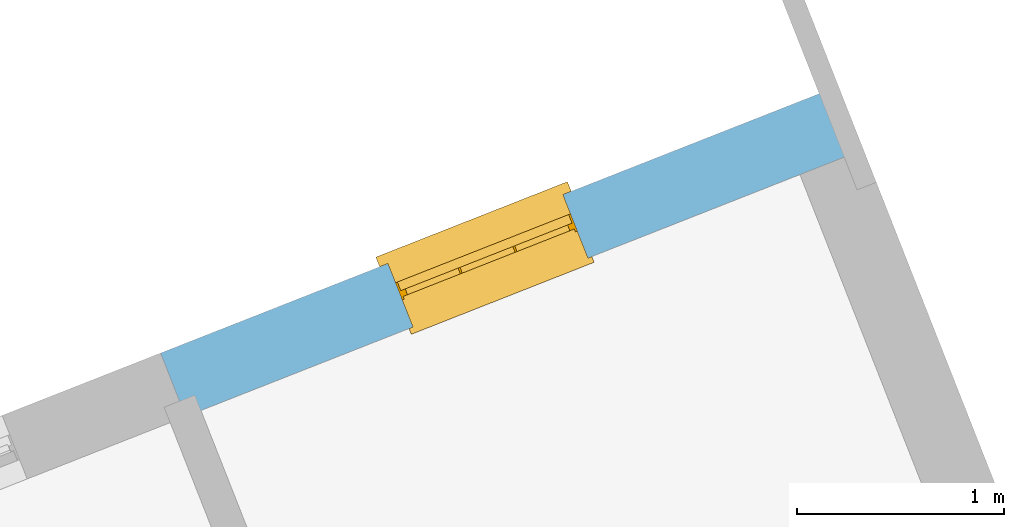
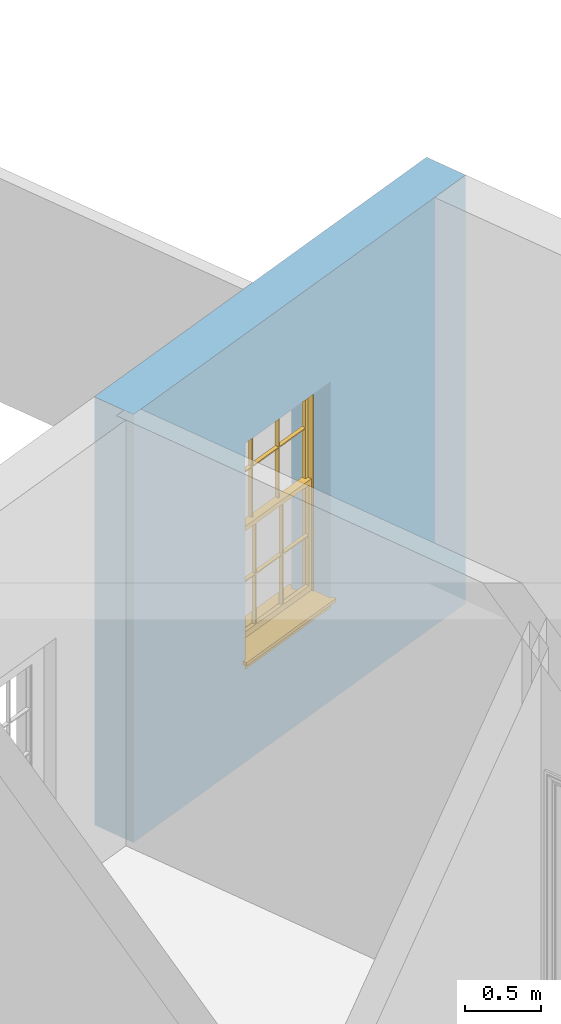
# One storey, part 7 of 8: 1 window, 1 opening, plus 1 element that does not belong to this part.
"""IFC2X3 building model written with IfcOpenShell, lengths in metres."""

from ifc_helpers import new_model, si_unit, frame, origin, place, context, subcontext, project, spatial, polyline, outline, extrude, faceted_brep, material, layer, layer_set, layer_usage, element, fill, save


model = new_model("IFC2X3")

# Units and contexts
model_context = context("Model", 3, world=origin())
body_context = subcontext(model_context, "Body", "Model", "MODEL_VIEW")
ifc_project = project(units=[si_unit("PLANEANGLEUNIT", "RADIAN"), si_unit("MASSUNIT", "GRAM", prefix="KILO"), si_unit("FORCEUNIT", "NEWTON", prefix="KILO"), si_unit("LENGTHUNIT", "METRE")], contexts=[model_context])

# Site, building, storey
site_placement = place(None, origin())
site = spatial("IfcSite", under=ifc_project, at=site_placement, CompositionType="ELEMENT")
building_placement = place(None, origin())
building = spatial("IfcBuilding", under=site, at=building_placement, Name="Building plot-4", CompositionType="ELEMENT")
storey_placement = place(None, frame((0.0, 0.0, 3.0)))
storey = spatial("IfcBuildingStorey", under=building, at=storey_placement, Name="Floor 0", CompositionType="ELEMENT", Elevation=3.0)

# Wall, opening, window
ifc_material = material(Name="Masonry")
ifc_layer = layer(ifc_material, 0.33, ventilated=False)
ifc_layer_set = layer_set([ifc_layer], Name="My Wall")
ifc_layer_usage = layer_usage(ifc_layer_set, "AXIS2", "NEGATIVE", 0.08)
wall_placement = place(storey_placement, origin())
wall = element("IfcWallStandardCase", 1, at=wall_placement, inside=storey, material=ifc_layer_usage, Name="exterior", context=body_context, shape_type="SweptSolid", body=[
    extrude(outline(polyline([(55.3138387008242, 55.0638365529384), (55.192917321505, 55.3708838131828), (51.9157706887258, 54.0802776349957), (52.0366920680449, 53.7732303747513), (55.3138387008242, 55.0638365529384)])), origin(), (0.0, 0.0, 1.0), 3.45),
])
opening_placement = place(storey_placement, frame((0.0, 0.0, 0.75)))
opening = element("IfcOpeningElement", 2, at=opening_placement, cuts=wall, Name="Opening", ObjectType="Opening", context=body_context, shape_type="SweptSolid", body=[
    extrude(outline(polyline([(53.8613912653598, 54.8465021034084), (53.0146851840799, 54.5130522392253), (53.1356065633991, 54.2060049789809), (53.9823126446789, 54.539454843164), (53.8613912653598, 54.8465021034084)])), origin(), (0.0, 0.0, 1.0), 1.82),
])
window_placement = place(storey_placement, frame((53.9529983709046, 54.6138905426172, 0.75), z_axis=(0.0, 0.0, 1.0), x_axis=(-0.846706081279848, -0.333449864183102, 0.0)))
window = element("IfcWindow", 3, at=window_placement, inside=storey, Name="living window", OverallHeight=1.82, OverallWidth=0.91, context=body_context, shape_type="Brep", held_by="IfcProductRepresentation", body=[
    faceted_brep([(0.033125, -0.105, 0.975209), (0.01, -0.105, 0.975209), (0.033125, -0.105, 1.376042), (0.876875, -0.105, 0.975209), (0.876875, -0.105, 1.376042), (0.9, -0.105, 0.975209), (0.876875, -0.105, 1.386042), (0.876875, -0.105, 1.786875), (0.9, -0.105, 1.81), (0.033125, -0.105, 1.786875), (0.033125, -0.105, 1.386042), (0.01, -0.105, 1.81), (0.876875, -0.135, 1.376042), (0.876875, -0.135, 0.975209), (0.9, -0.135, 0.937083), (0.033125, -0.135, 1.786875), (0.01, -0.135, 1.81), (0.033125, -0.135, 1.386042), (0.01, -0.135, 0.937083), (0.033125, -0.135, 0.975209), (0.033125, -0.135, 1.376042), (0.876875, -0.135, 1.786875), (0.876875, -0.135, 1.386042), (0.9, -0.135, 1.81), (0.033125, -0.105, 0.937083), (0.01, -0.105, 0.937083), (0.033125, -0.105, 0.53625), (0.876875, -0.105, 0.937083), (0.876875, -0.105, 0.53625), (0.9, -0.105, 0.937083), (0.876875, -0.105, 0.52625), (0.876875, -0.105, 0.125417), (0.9, -0.105, 0.077167), (0.033125, -0.105, 0.125417), (0.033125, -0.105, 0.52625), (0.01, -0.105, 0.077167), (-0.0425, -0.25, 0.01), (-0.0425, -0.3, 0.001667), (0.0, -0.25, 0.01), (0.9525, -0.25, 0.01), (0.91, -0.25, 0.01), (0.9525, -0.3, 0.001667), (-0.02, 0.08, 0.077167), (0.0, 0.08, 0.077167), (-0.02, 0.11, 0.077167), (0.0, -0.06, 0.077167), (0.01, -0.06, 0.077167), (0.91, -0.06, 0.077167), (0.91, 0.08, 0.077167), (0.9, -0.06, 0.077167), (0.93, 0.08, 0.077167), (0.93, 0.11, 0.077167), (0.01, -0.075, 0.975209), (0.9, -0.075, 0.975209), (0.876875, -0.075, 0.125417), (0.876875, -0.075, 0.52625), (0.9, -0.075, 0.077167), (0.876875, -0.075, 0.53625), (0.876875, -0.075, 0.937083), (0.033125, -0.075, 0.125417), (0.01, -0.075, 0.077167), (0.033125, -0.075, 0.52625), (0.033125, -0.075, 0.937083), (0.033125, -0.075, 0.53625), (-0.02, 0.08, 0.052167), (-0.02, 0.11, 0.052167), (0.93, 0.11, 0.052167), (0.93, 0.08, 0.052167), (0.91, 0.08, 0.052167), (0.0, 0.08, 0.052167), (0.91, -0.15, 0.026667), (0.0, -0.15, 0.026667), (-0.0425, -0.3, -0.123333), (0.9525, -0.3, -0.123333), (-0.0425, -0.25, -0.123333), (0.9525, -0.25, -0.123333), (0.01, -0.06, 1.81), (0.9, -0.06, 1.81), (0.0, -0.06, 1.82), (0.91, -0.06, 1.82), (0.01, -0.15, 0.077167), (0.9, -0.15, 0.077167), (0.592292, -0.105, 0.125417), (0.592292, -0.075, 0.125417), (0.317708, -0.075, 0.125417), (0.317708, -0.105, 0.125417), (0.592292, -0.105, 0.53625), (0.317708, -0.105, 0.53625), (0.317708, -0.105, 0.52625), (0.592292, -0.105, 0.52625), (0.592292, -0.075, 0.53625), (0.317708, -0.075, 0.53625), (0.592292, -0.135, 1.386042), (0.592292, -0.105, 1.386042), (0.317708, -0.105, 1.386042), (0.317708, -0.135, 1.386042), (0.317708, -0.135, 1.376042), (0.592292, -0.135, 1.376042), (0.317708, -0.105, 1.376042), (0.592292, -0.105, 1.376042), (0.602292, -0.135, 1.376042), (0.592292, -0.135, 0.975209), (0.602292, -0.135, 0.975209), (0.602292, -0.105, 0.975209), (0.592292, -0.105, 0.975209), (0.602292, -0.105, 1.376042), (0.602292, -0.075, 0.53625), (0.602292, -0.105, 0.53625), (0.317708, -0.075, 0.52625), (0.307708, -0.075, 0.125417), (0.307708, -0.075, 0.52625), (0.602292, -0.075, 0.52625), (0.602292, -0.075, 0.125417), (0.592292, -0.075, 0.52625), (0.307708, -0.075, 0.53625), (0.317708, -0.075, 0.937083), (0.307708, -0.075, 0.937083), (0.602292, -0.075, 0.937083), (0.592292, -0.075, 0.937083), (0.307708, -0.105, 0.52625), (0.307708, -0.105, 0.125417), (0.307708, -0.105, 0.53625), (0.307708, -0.105, 0.937083), (0.592292, -0.105, 0.937083), (0.317708, -0.105, 0.937083), (0.602292, -0.105, 0.937083), (0.602292, -0.105, 0.52625), (0.602292, -0.105, 0.125417), (0.307708, -0.135, 1.386042), (0.307708, -0.135, 1.376042), (0.307708, -0.135, 0.975209), (0.317708, -0.135, 0.975209), (0.317708, -0.135, 1.786875), (0.307708, -0.135, 1.786875), (0.602292, -0.135, 1.786875), (0.592292, -0.135, 1.786875), (0.602292, -0.135, 1.386042), (0.602292, -0.105, 1.386042), (0.307708, -0.105, 1.386042), (0.307708, -0.105, 1.786875), (0.317708, -0.105, 1.786875), (0.592292, -0.105, 1.786875), (0.602292, -0.105, 1.786875), (0.307708, -0.105, 1.376042), (0.317708, -0.105, 0.975209), (0.307708, -0.105, 0.975209), (0.91, -0.15, 1.82), (0.9, -0.15, 1.81), (0.01, -0.15, 1.81), (0.0, -0.15, 1.82), (0.91, -0.25, 0.0), (0.0, -0.25, 0.0), (0.91, 0.08, 0.0), (0.0, 0.08, 0.0)], [[[0, 1, 2]], [[3, 4, 5]], [[6, 7, 8]], [[9, 10, 11]], [[12, 13, 14]], [[15, 16, 17]], [[18, 19, 20]], [[21, 22, 23]], [[24, 25, 26]], [[27, 28, 29]], [[30, 31, 32]], [[33, 34, 35]], [[14, 27, 29]], [[25, 24, 18]], [[36, 37, 38]], [[39, 40, 41]], [[42, 43, 44]], [[45, 46, 43]], [[47, 48, 49]], [[50, 51, 48]], [[1, 0, 52]], [[5, 53, 3]], [[54, 55, 56]], [[57, 58, 53]], [[59, 60, 61]], [[62, 63, 52]], [[48, 43, 46, 49]], [[51, 44, 43, 48]], [[64, 42, 44, 65]], [[65, 44, 51, 66]], [[66, 51, 50, 67]], [[65, 66, 68, 69]], [[60, 56, 49, 46]], [[70, 71, 38, 40]], [[37, 41, 40, 38]], [[37, 72, 73, 41]], [[74, 75, 73, 72]], [[8, 11, 76, 77]], [[76, 78, 79, 77]], [[32, 35, 80, 81]], [[81, 80, 71, 70]], [[82, 83, 84, 85]], [[86, 87, 88, 89]], [[86, 90, 91, 87]], [[92, 93, 94, 95]], [[92, 95, 96, 97]], [[96, 98, 99, 97]], [[100, 97, 101, 102]], [[103, 104, 99, 105]], [[97, 99, 104, 101]], [[102, 103, 105, 100]], [[28, 57, 106, 107]], [[108, 84, 109, 110]], [[111, 112, 83, 113]], [[114, 110, 61, 63]], [[90, 113, 108, 91]], [[115, 91, 114, 116]], [[117, 106, 90, 118]], [[111, 106, 57, 55]], [[119, 110, 109, 120]], [[34, 61, 110, 119]], [[89, 113, 83, 82]], [[88, 108, 113, 89]], [[85, 84, 108, 88]], [[121, 114, 63, 26]], [[122, 116, 114, 121]], [[123, 118, 90, 86]], [[87, 91, 115, 124]], [[107, 106, 117, 125]], [[126, 111, 55, 30]], [[127, 112, 111, 126]], [[126, 30, 28, 107]], [[88, 119, 120, 85]], [[126, 89, 82, 127]], [[125, 123, 86, 107]], [[121, 26, 34, 119]], [[124, 122, 121, 87]], [[128, 17, 20, 129]], [[96, 129, 130, 131]], [[132, 133, 128, 95]], [[134, 135, 92, 136]], [[100, 12, 22, 136]], [[137, 6, 4, 105]], [[94, 138, 139, 140]], [[137, 93, 141, 142]], [[99, 98, 94, 93]], [[143, 2, 10, 138]], [[144, 145, 143, 98]], [[129, 143, 145, 130]], [[20, 2, 143, 129]], [[131, 144, 98, 96]], [[128, 138, 10, 17]], [[133, 139, 138, 128]], [[135, 141, 93, 92]], [[95, 94, 140, 132]], [[22, 6, 137, 136]], [[136, 137, 142, 134]], [[100, 105, 4, 12]], [[107, 86, 89, 126]], [[106, 111, 113, 90]], [[91, 108, 110, 114]], [[87, 121, 119, 88]], [[97, 100, 136, 92]], [[129, 96, 95, 128]], [[98, 143, 138, 94]], [[105, 99, 93, 137]], [[131, 101, 104, 144]], [[124, 115, 118, 123]], [[132, 140, 141, 135]], [[120, 109, 59, 33]], [[15, 9, 139, 133]], [[134, 142, 7, 21]], [[31, 54, 112, 127]], [[36, 74, 72, 37]], [[39, 41, 73, 75]], [[18, 14, 101, 131]], [[23, 16, 132, 135]], [[83, 56, 60, 84]], [[52, 53, 118, 115]], [[53, 52, 144, 104]], [[11, 8, 141, 140]], [[14, 18, 124, 123]], [[2, 1, 11, 10]], [[8, 5, 4, 6]], [[57, 53, 56, 55]], [[60, 52, 63, 61]], [[26, 25, 35, 34]], [[32, 29, 28, 30]], [[14, 23, 22, 12]], [[18, 20, 17, 16]], [[19, 0, 2, 20]], [[17, 10, 9, 15]], [[12, 4, 3, 13]], [[21, 7, 6, 22]], [[27, 58, 57, 28]], [[30, 55, 54, 31]], [[33, 59, 61, 34]], [[26, 63, 62, 24]], [[5, 8, 77, 53]], [[76, 11, 1, 52]], [[46, 45, 78, 76]], [[49, 77, 79, 47]], [[70, 146, 147, 81]], [[71, 80, 148, 149]], [[19, 130, 145, 0]], [[102, 13, 3, 103]], [[116, 122, 24, 62]], [[29, 32, 81, 14]], [[80, 35, 25, 18]], [[60, 46, 76, 52]], [[77, 49, 56, 53]], [[23, 14, 81, 147]], [[16, 148, 80, 18]], [[35, 85, 120]], [[120, 33, 35]], [[127, 82, 32]], [[32, 31, 127]], [[32, 82, 85, 35]], [[102, 101, 14]], [[14, 13, 102]], [[18, 131, 130]], [[130, 19, 18]], [[134, 21, 23]], [[23, 135, 134]], [[16, 15, 133]], [[133, 132, 16]], [[11, 140, 139]], [[139, 9, 11]], [[142, 141, 8]], [[8, 7, 142]], [[23, 147, 148, 16]], [[146, 149, 148, 147]], [[52, 115, 116]], [[116, 62, 52]], [[118, 53, 117]], [[58, 117, 53]], [[27, 125, 117, 58]], [[56, 83, 112]], [[112, 54, 56]], [[109, 84, 60]], [[60, 59, 109]], [[125, 27, 14]], [[14, 123, 125]], [[122, 124, 18]], [[18, 24, 122]], [[145, 144, 52]], [[52, 0, 145]], [[103, 3, 53]], [[53, 104, 103]], [[79, 78, 149, 146]], [[78, 45, 71, 149]], [[146, 70, 47, 79]], [[150, 75, 74, 151]], [[68, 66, 67]], [[48, 68, 67, 50]], [[69, 64, 65]], [[42, 64, 69, 43]], [[69, 68, 152, 153]], [[70, 68, 48, 47]], [[150, 152, 68, 70]], [[43, 69, 71, 45]], [[69, 153, 151, 71]], [[152, 150, 151, 153]], [[38, 151, 74, 36]], [[71, 151, 38]], [[39, 75, 150, 40]], [[40, 150, 70]]]),
])
fill(opening, window)

save(model, "model.ifc")
